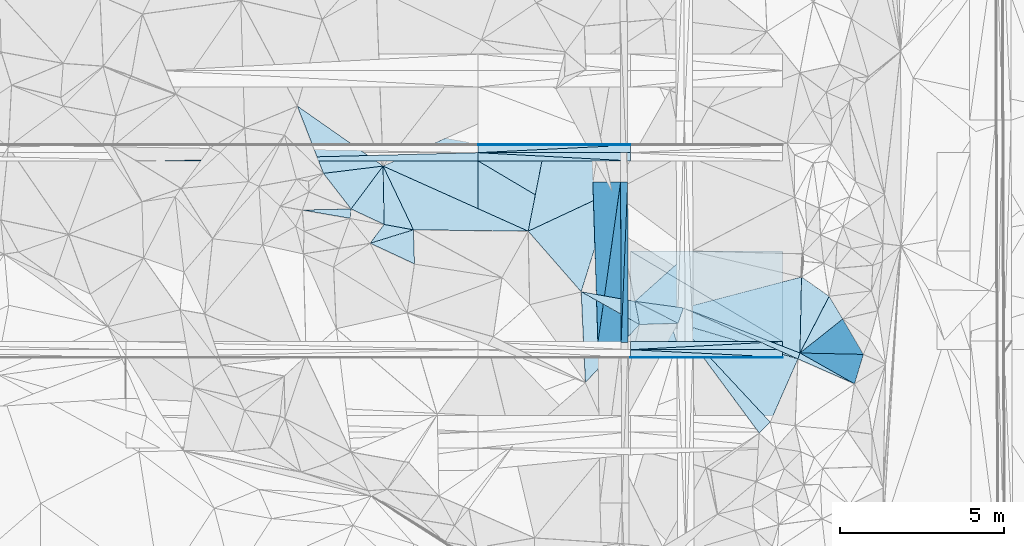
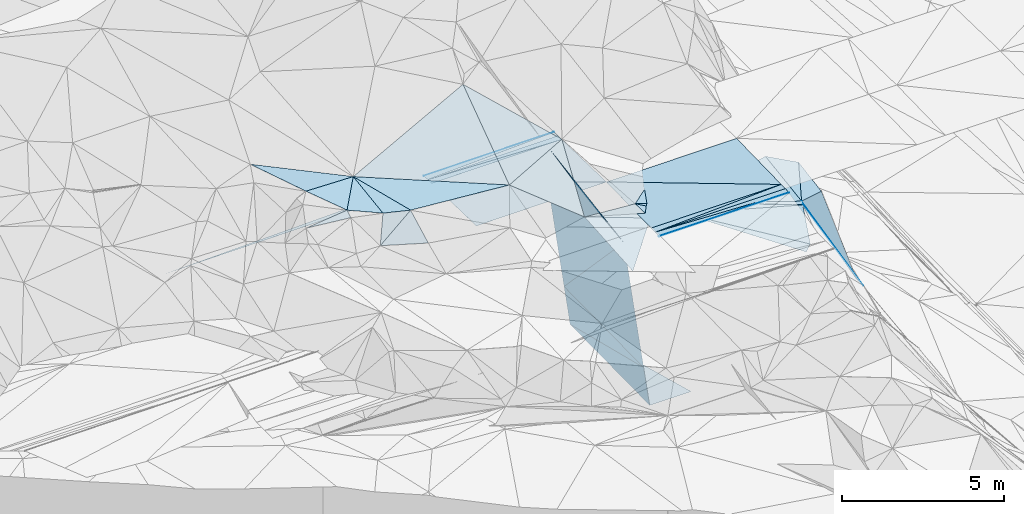
# One storey, part 61 of 275: 48 plates.
"""IFC2X3 building model written with IfcOpenShell, lengths in millimetres."""

from ifc_helpers import new_model, si_unit, frame, origin_with_axes, place, context, subcontext, project, spatial, polyline, outline, extrude, material, type_object, element, save


model = new_model("IFC2X3")

# Units and contexts
model_context = context("Model", 3, precision=1e-05, world=origin_with_axes())
body_context = subcontext(model_context, "Body", "Model", "MODEL_VIEW")
ifc_project = project(units=[si_unit("LENGTHUNIT", "METRE", prefix="MILLI"), si_unit("AREAUNIT", "SQUARE_METRE"), si_unit("VOLUMEUNIT", "CUBIC_METRE"), si_unit("MASSUNIT", "GRAM", prefix="KILO"), si_unit("TIMEUNIT", "SECOND"), si_unit("PLANEANGLEUNIT", "RADIAN"), si_unit("SOLIDANGLEUNIT", "STERADIAN"), si_unit("THERMODYNAMICTEMPERATUREUNIT", "DEGREE_CELSIUS"), si_unit("LUMINOUSINTENSITYUNIT", "LUMEN")], contexts=[model_context])

# Site, building, storey
site_placement = place(None, origin_with_axes())
site = spatial("IfcSite", under=ifc_project, at=site_placement, CompositionType="ELEMENT")
building_placement = place(site_placement, origin_with_axes())
building = spatial("IfcBuilding", under=site, at=building_placement, Name="Undefined", CompositionType="ELEMENT")
storey_placement = place(building_placement, origin_with_axes())
storey = spatial("IfcBuildingStorey", under=building, at=storey_placement, Name="Undefined", CompositionType="ELEMENT", Elevation=0.0)

# Plates
ifc_material = material()
plate_type_1 = type_object("IfcPlateType", PredefinedType="NOTDEFINED")
plate_1_placement = place(storey_placement, frame((-100830.589611758, 60542.6808444569, 49114.2541550051), z_axis=(0.00445958464702882, 0.0249916867668201, -0.999677711913857), x_axis=(-0.999990054538875, 5.7357962472799e-05, -0.00445954408009802)))
element("IfcPlate", 1, at=plate_1_placement, inside=storey, type_object=plate_type_1, material=ifc_material, Name="00_PR", context=body_context, shape_type="SweptSolid", body=[
    extrude(outline(polyline([(0.0, 0.0), (4638.8154296875, -1.62399373948574e-08), (4638.5087890625, 2750.85913085938), (0.0, 0.0)])), frame((-8.85201319254618e-08, 2.18876761149539e-07, -0.5000001331573), z_axis=(0.0, 0.0, 1.0), x_axis=(1.0, 0.0, 0.0)), (0.0, 0.0, 1.0), 1.0),
])
plate_2_placement = place(storey_placement, frame((-110107.812661228, 66043.1876384152, 49060.924162094), z_axis=(0.00703319088817578, -0.0249919755993871, -0.999662910876246), x_axis=(0.99997523963564, -5.72709999785377e-05, 0.00703681999743575)))
element("IfcPlate", 2, at=plate_2_placement, inside=storey, type_object=plate_type_1, material=ifc_material, Name="00_PR", context=body_context, shape_type="SweptSolid", body=[
    extrude(outline(polyline([(0.0, 0.0), (4638.88525390625, 2.71393219009042e-09), (4639.36865234375, 2750.85913085938), (0.0, 0.0)])), frame((-8.85201319254618e-08, 2.18876761149539e-07, -0.5000001331573), z_axis=(0.0, 0.0, 1.0), x_axis=(1.0, 0.0, 0.0)), (0.0, 0.0, 1.0), 1.0),
])
plate_3_placement = place(storey_placement, frame((-105469.201325438, 63292.9469357661, 49162.3171559692), z_axis=(0.00445958464702882, 0.0249916867668201, -0.999677711913857), x_axis=(0.999990054538811, -5.7357974325105e-05, 0.00445954409423353)))
element("IfcPlate", 3, at=plate_3_placement, inside=storey, type_object=plate_type_1, material=ifc_material, Name="00_PR", context=body_context, shape_type="SweptSolid", body=[
    extrude(outline(polyline([(0.0, 0.0), (4638.8154296875, -1.62399373948574e-08), (4638.5087890625, 2750.85913085938), (0.0, 0.0)])), frame((-8.85201319254618e-08, 2.18876761149539e-07, -0.5000001331573), z_axis=(0.0, 0.0, 1.0), x_axis=(1.0, 0.0, 0.0)), (0.0, 0.0, 1.0), 1.0),
])
plate_4_placement = place(storey_placement, frame((-105469.200038156, 63292.9219439017, 49162.3171634529), z_axis=(0.00703319088817578, -0.0249919755993871, -0.999662910876246), x_axis=(-0.999975239635043, 5.72709690146696e-05, -0.00703682008264182)))
element("IfcPlate", 4, at=plate_4_placement, inside=storey, type_object=plate_type_1, material=ifc_material, Name="00_PR", context=body_context, shape_type="SweptSolid", body=[
    extrude(outline(polyline([(0.0, 0.0), (4638.88525390625, 2.71393219009042e-09), (4639.36865234375, 2750.85913085938), (0.0, 0.0)])), frame((-8.85201319254618e-08, 2.18876761149539e-07, -0.5000001331573), z_axis=(0.0, 0.0, 1.0), x_axis=(1.0, 0.0, 0.0)), (0.0, 0.0, 1.0), 1.0),
])
plate_type_2 = type_object("IfcPlateType", PredefinedType="NOTDEFINED")
plate_5_placement = place(storey_placement, frame((-105750.211963608, 60512.2783129229, 43954.7062906531), z_axis=(-0.989949462688616, -0.000459142367813095, -0.141420827712214), x_axis=(0.0389520529233539, 0.960431065069933, -0.275780541049744)))
element("IfcPlate", 5, at=plate_5_placement, inside=storey, type_object=plate_type_2, material=ifc_material, Name="00_PR", context=body_context, shape_type="SweptSolid", body=[
    extrude(outline(polyline([(0.0, 0.0), (5087.06298828125, -9.02218744158745e-10), (422.780456542969, 1455.05151367188), (0.0, 0.0)])), frame((-8.85201319254618e-08, 2.18876761149539e-07, -0.5000001331573), z_axis=(0.0, 0.0, 1.0), x_axis=(1.0, 0.0, 0.0)), (0.0, 0.0, 1.0), 1.0),
])
plate_6_placement = place(storey_placement, frame((-105552.060415257, 65398.0516855219, 42551.7932908244), z_axis=(-0.989949462688616, -0.000459142367813095, -0.141420827712214), x_axis=(-0.0389520529001287, -0.960431065076031, 0.275780541031789)))
element("IfcPlate", 6, at=plate_6_placement, inside=storey, type_object=plate_type_2, material=ifc_material, Name="00_PR", context=body_context, shape_type="SweptSolid", body=[
    extrude(outline(polyline([(0.0, 0.0), (5087.06298828125, -9.02218744158745e-10), (422.614044189453, 1455.09997558594), (0.0, 0.0)])), frame((-8.85201319254618e-08, 2.18876761149539e-07, -0.5000001331573), z_axis=(0.0, 0.0, 1.0), x_axis=(1.0, 0.0, 0.0)), (0.0, 0.0, 1.0), 1.0),
])
plate_type_3 = type_object("IfcPlateType", PredefinedType="NOTDEFINED")
for number, where, z_axis, x_axis, name in (
    (7, (-100830.589611758, 60542.6808444569, 49114.2541550051), (0.00445958464702882, 0.0249916867668201, -0.999677711913857), (-5.72779639714365e-05, -0.999687644771442, -0.0249921909916474), "00_PR"),
    (8, (-105469.373205973, 60292.9469153299, 49087.3171553601), (0.00445958464702882, 0.0249916867668201, -0.999677711913857), (5.72779615274784e-05, 0.999687644771121, 0.0249921910044782), "00_PR"),
):
    element("IfcPlate", number, at=place(storey_placement, frame(where, z_axis=z_axis, x_axis=x_axis)), inside=storey, type_object=plate_type_3, material=ifc_material, Name=name, context=body_context, shape_type="SweptSolid", body=[
        extrude(outline(polyline([(0.0, 0.0), (250.078109741211, 1.02591002359986e-09), (250.594833374023, 4638.8154296875), (0.0, 0.0)])), frame((-8.85201319254618e-08, 2.18876761149539e-07, -0.5000001331573), z_axis=(0.0, 0.0, 1.0), x_axis=(1.0, 0.0, 0.0)), (0.0, 0.0, 1.0), 1.0),
    ])
for number, where, z_axis, x_axis, name in (
    (9, (-105469.042478086, 66042.9219653409, 49093.5671630023), (0.00703319088817578, -0.0249919755993871, -0.999662910876246), (-0.999975239635043, 5.72709690146696e-05, -0.00703682008264182), "00_PR"),
    (10, (-110107.798337881, 66293.1876381084, 49054.6741627501), (0.00703319088817578, -0.0249919755993871, -0.999662910876246), (0.99997523963564, -5.72709999785377e-05, 0.00703681999743575), "00_PR"),
):
    element("IfcPlate", number, at=place(storey_placement, frame(where, z_axis=z_axis, x_axis=x_axis)), inside=storey, type_object=plate_type_3, material=ifc_material, Name=name, context=body_context, shape_type="SweptSolid", body=[
        extrude(outline(polyline([(0.0, 0.0), (4638.88525390625, 2.71393219009042e-09), (4638.92919921875, 250.078109741211), (0.0, 0.0)])), frame((-8.85201319254618e-08, 2.18876761149539e-07, -0.5000001331573), z_axis=(0.0, 0.0, 1.0), x_axis=(1.0, 0.0, 0.0)), (0.0, 0.0, 1.0), 1.0),
    ])
plate_7_placement = place(storey_placement, frame((-119776.166734468, 66043.7427297711, 48980.4271662069), z_axis=(0.00832149793297365, -0.0249918019511436, -0.9996530210565), x_axis=(0.999637887760612, 0.0257907600207236, 0.00767659110902143)))
element("IfcPlate", 11, at=plate_7_placement, inside=storey, type_object=plate_type_3, material=ifc_material, Name="00_PR", context=body_context, shape_type="SweptSolid", body=[
    extrude(outline(polyline([(0.0, 0.0), (9671.87109375, 1.0710209608078e-08), (9665.45703125, 249.995849609375), (0.0, 0.0)])), frame((-8.85201319254618e-08, 2.18876761149539e-07, -0.5000001331573), z_axis=(0.0, 0.0, 1.0), x_axis=(1.0, 0.0, 0.0)), (0.0, 0.0, 1.0), 1.0),
])
plate_type_4 = type_object("IfcPlateType", PredefinedType="NOTDEFINED")
plate_8_placement = place(storey_placement, frame((-105469.387528918, 60042.9593598603, 49074.8176223799), z_axis=(0.00445706800429549, 0.0498862544457176, -0.998744960519042), x_axis=(0.999980022930594, 0.00425411303893104, 0.00467506812571352)))
element("IfcPlate", 12, at=plate_8_placement, inside=storey, type_object=plate_type_4, material=ifc_material, Name="00_PR", context=body_context, shape_type="SweptSolid", body=[
    extrude(outline(polyline([(0.0, 0.0), (4638.86279296875, -3.32511262968183e-09), (4638.77197265625, 20.0250549316406), (0.0, 0.0)])), frame((-8.85201319254618e-08, 2.18876761149539e-07, -0.5000001331573), z_axis=(0.0, 0.0, 1.0), x_axis=(1.0, 0.0, 0.0)), (0.0, 0.0, 1.0), 1.0),
])
plate_9_placement = place(storey_placement, frame((-105469.386444849, 60062.9597101127, 49075.81762361), z_axis=(0.00445684475219927, 0.0499360670244888, -0.998742472184387), x_axis=(0.999990054538811, -5.7357974325105e-05, 0.00445954409423353)))
element("IfcPlate", 13, at=plate_9_placement, inside=storey, type_object=plate_type_4, material=ifc_material, Name="00_PR", context=body_context, shape_type="SweptSolid", body=[
    extrude(outline(polyline([(0.0, 0.0), (4638.8154296875, -1.62399373948574e-08), (-0.00440195994451642, 20.0253086090088), (0.0, 0.0)])), frame((-8.85201319254618e-08, 2.18876761149539e-07, -0.5000001331573), z_axis=(0.0, 0.0, 1.0), x_axis=(1.0, 0.0, 0.0)), (0.0, 0.0, 1.0), 1.0),
])
plate_10_placement = place(storey_placement, frame((-105469.013835611, 66542.9094938357, 49074.8176311458), z_axis=(0.00702518057718914, -0.0499383774070755, -0.998727593140295), x_axis=(-7.46349832174646e-05, -0.998752262639263, 0.0499390859204745)))
element("IfcPlate", 14, at=plate_10_placement, inside=storey, type_object=plate_type_4, material=ifc_material, Name="00_PR", context=body_context, shape_type="SweptSolid", body=[
    extrude(outline(polyline([(0.0, 0.0), (20.0243949890137, 1.30967237055302e-10), (18.4751071929932, 4638.884765625), (0.0, 0.0)])), frame((-8.85201319254618e-08, 2.18876761149539e-07, -0.5000001331573), z_axis=(0.0, 0.0, 1.0), x_axis=(1.0, 0.0, 0.0)), (0.0, 0.0, 1.0), 1.0),
])
plate_11_placement = place(storey_placement, frame((-110107.785515668, 66523.1757512624, 49043.1746305626), z_axis=(0.00702518057718914, -0.0499383774070755, -0.998727593140295), x_axis=(7.46349675932083e-05, 0.998752262639191, -0.0499390859219244)))
element("IfcPlate", 15, at=plate_11_placement, inside=storey, type_object=plate_type_4, material=ifc_material, Name="00_PR", context=body_context, shape_type="SweptSolid", body=[
    extrude(outline(polyline([(0.0, 0.0), (20.0243949890137, 1.30967237055302e-10), (18.4750175476074, 4638.884765625), (0.0, 0.0)])), frame((-8.85201319254618e-08, 2.18876761149539e-07, -0.5000001331573), z_axis=(0.0, 0.0, 1.0), x_axis=(1.0, 0.0, 0.0)), (0.0, 0.0, 1.0), 1.0),
])
plate_type_5 = type_object("IfcPlateType", PredefinedType="NOTDEFINED")
plate_12_placement = place(storey_placement, frame((-112075.543551472, 63943.371448506, 50019.5088277539), z_axis=(-0.0790529331434514, 0.169753305457611, -0.982310770096527), x_axis=(-0.97775423595403, 0.178846539819995, 0.109592742772353)))
element("IfcPlate", 16, at=plate_12_placement, inside=storey, type_object=plate_type_5, material=ifc_material, Name="00", context=body_context, shape_type="SweptSolid", body=[
    extrude(outline(polyline([(0.0, 0.0), (912.469177246094, -5.08589437231421e-09), (1295.93420410156, 1764.86669921875), (0.0, 0.0)])), frame((-8.85201319254618e-08, 2.18876761149539e-07, -0.5000001331573), z_axis=(0.0, 0.0, 1.0), x_axis=(1.0, 0.0, 0.0)), (0.0, 0.0, 1.0), 1.0),
])
plate_type_6 = type_object("IfcPlateType", PredefinedType="NOTDEFINED")
for number, where, z_axis, x_axis, name in (
    (17, (-100830.617173414, 60062.6936343735, 49096.5046243823), (0.00445684475219927, 0.0499360670244888, -0.998742472184387), (-0.999990054538875, 5.7357962472799e-05, -0.00445954408009802), "00_PR"),
    (18, (-105469.373208307, 60292.9593863824, 49087.317623531), (0.00445684475219927, 0.0499360670244888, -0.998742472184387), (0.999990054538811, -5.7357974325105e-05, 0.00445954409423353), "00_PR"),
):
    element("IfcPlate", number, at=place(storey_placement, frame(where, z_axis=z_axis, x_axis=x_axis)), inside=storey, type_object=plate_type_6, material=ifc_material, Name=name, context=body_context, shape_type="SweptSolid", body=[
        extrude(outline(polyline([(0.0, 0.0), (4638.8154296875, -1.62399373948574e-08), (4638.76416015625, 230.286987304688), (0.0, 0.0)])), frame((-8.85201319254618e-08, 2.18876761149539e-07, -0.5000001331573), z_axis=(0.0, 0.0, 1.0), x_axis=(1.0, 0.0, 0.0)), (0.0, 0.0, 1.0), 1.0),
    ])
for number, where, z_axis, x_axis, name in (
    (19, (-105469.015328901, 66522.9100819823, 49075.817631294), (0.00702518115586618, -0.0499366476229546, -0.998727679627389), (-5.57099735653163e-05, -0.998752343725082, 0.0499374889242045), "00_PR"),
    (20, (-110107.798341937, 66293.1751620054, 49054.6746301273), (0.00702518115586618, -0.0499366476229546, -0.998727679627389), (5.57099558727869e-05, 0.998752343723243, -0.049937488961006), "00_PR"),
):
    element("IfcPlate", number, at=place(storey_placement, frame(where, z_axis=z_axis, x_axis=x_axis)), inside=storey, type_object=plate_type_6, material=ifc_material, Name=name, context=body_context, shape_type="SweptSolid", body=[
        extrude(outline(polyline([(0.0, 0.0), (230.28791809082, 9.89530235528946e-10), (228.650894165039, 4638.884765625), (0.0, 0.0)])), frame((-8.85201319254618e-08, 2.18876761149539e-07, -0.5000001331573), z_axis=(0.0, 0.0, 1.0), x_axis=(1.0, 0.0, 0.0)), (0.0, 0.0, 1.0), 1.0),
    ])
plate_type_7 = type_object("IfcPlateType", PredefinedType="NOTDEFINED")
plate_13_placement = place(storey_placement, frame((-112999.778043075, 65885.4205597464, 50429.5035751612), z_axis=(-0.117700150187299, -0.0215803549464643, -0.992814666957671), x_axis=(-0.985437579645011, -0.121008542112086, 0.119455888759363)))
element("IfcPlate", 21, at=plate_13_placement, inside=storey, type_object=plate_type_7, material=ifc_material, Name="00", context=body_context, shape_type="SweptSolid", body=[
    extrude(outline(polyline([(0.0, 0.0), (1841.68395996094, 1.0433723218739e-08), (2385.75122070313, 2134.59375), (0.0, 0.0)])), frame((-8.85201319254618e-08, 2.18876761149539e-07, -0.5000001331573), z_axis=(0.0, 0.0, 1.0), x_axis=(1.0, 0.0, 0.0)), (0.0, 0.0, 1.0), 1.0),
])
plate_type_8 = type_object("IfcPlateType", PredefinedType="NOTDEFINED")
plate_14_placement = place(storey_placement, frame((-106016.707017982, 65102.1914454175, 49869.5117628019), z_axis=(-0.059004241128737, 0.207589575508006, -0.976434876307287), x_axis=(-0.905266208865445, -0.423375243554277, -0.0353057251977836)))
element("IfcPlate", 22, at=plate_14_placement, inside=storey, type_object=plate_type_8, material=ifc_material, Name="00", context=body_context, shape_type="SweptSolid", body=[
    extrude(outline(polyline([(0.0, 0.0), (2832.40185546875, -1.62981450557709e-09), (197.147171020508, 3649.33325195313), (0.0, 0.0)])), frame((-8.85201319254618e-08, 2.18876761149539e-07, -0.5000001331573), z_axis=(0.0, 0.0, 1.0), x_axis=(1.0, 0.0, 0.0)), (0.0, 0.0, 1.0), 1.0),
])
plate_type_9 = type_object("IfcPlateType", PredefinedType="NOTDEFINED")
plate_15_placement = place(storey_placement, frame((-105766.345772115, 65397.4307514834, 44051.793290675), z_axis=(-0.989949462688616, -0.000459142367813095, -0.141420827712214), x_axis=(-0.0999028479454266, -0.705520009970533, 0.701613096017721)))
element("IfcPlate", 23, at=plate_15_placement, inside=storey, type_object=plate_type_9, material=ifc_material, Name="00_PR", context=body_context, shape_type="SweptSolid", body=[
    extrude(outline(polyline([(0.0, 0.0), (6927.90966796875, -9.61881596595049e-09), (4237.13232421875, 4214.724609375), (0.0, 0.0)])), frame((-8.85201319254618e-08, 2.18876761149539e-07, -0.5000001331573), z_axis=(0.0, 0.0, 1.0), x_axis=(1.0, 0.0, 0.0)), (0.0, 0.0, 1.0), 1.0),
])
plate_type_10 = type_object("IfcPlateType", PredefinedType="NOTDEFINED")
plate_16_placement = place(storey_placement, frame((-106458.463654874, 60509.6520100002, 48912.5052908891), z_axis=(-0.989949462688616, -0.000459142367813095, -0.141420827712214), x_axis=(0.0999028479470844, 0.705520009971267, -0.701613096016747)))
element("IfcPlate", 24, at=plate_16_placement, inside=storey, type_object=plate_type_10, material=ifc_material, Name="00_PR", context=body_context, shape_type="SweptSolid", body=[
    extrude(outline(polyline([(0.0, 0.0), (6927.90966796875, -9.61881596595049e-09), (3551.06591796875, 3531.47680664063), (0.0, 0.0)])), frame((-8.85201319254618e-08, 2.18876761149539e-07, -0.5000001331573), z_axis=(0.0, 0.0, 1.0), x_axis=(1.0, 0.0, 0.0)), (0.0, 0.0, 1.0), 1.0),
])
plate_type_11 = type_object("IfcPlateType", PredefinedType="NOTDEFINED")
plate_17_placement = place(storey_placement, frame((-105535.432843568, 60513.0827354153, 42454.2770998396), z_axis=(-7.36736984133596e-05, 0.0198704310227725, -0.999802560780455), x_axis=(-0.00330182709453269, 0.999797108690456, 0.0198705659718521)))
element("IfcPlate", 25, at=plate_17_placement, inside=storey, type_object=plate_type_11, material=ifc_material, Name="00_PR", context=body_context, shape_type="SweptSolid", body=[
    extrude(outline(polyline([(0.0, 0.0), (4885.97021484375, 1.59925548359752e-08), (0.599608778953552, 1480.00085449219), (0.0, 0.0)])), frame((-8.85201319254618e-08, 2.18876761149539e-07, -0.5000001331573), z_axis=(0.0, 0.0, 1.0), x_axis=(1.0, 0.0, 0.0)), (0.0, 0.0, 1.0), 1.0),
])
plate_type_12 = type_object("IfcPlateType", PredefinedType="NOTDEFINED")
plate_18_placement = place(storey_placement, frame((-104017.21366671, 61098.7763190205, 48799.5053855801), z_axis=(-0.0392953949728574, 0.141091818847094, -0.989216341650473), x_axis=(0.331602282612743, 0.935719227536978, 0.120289040995509)))
element("IfcPlate", 26, at=plate_18_placement, inside=storey, type_object=plate_type_12, material=ifc_material, Name="00", context=body_context, shape_type="SweptSolid", body=[
    extrude(outline(polyline([(0.0, 0.0), (498.798553466797, -4.65661287307739e-10), (157.979614257813, 3817.84521484375), (0.0, 0.0)])), frame((-8.85201319254618e-08, 2.18876761149539e-07, -0.5000001331573), z_axis=(0.0, 0.0, 1.0), x_axis=(1.0, 0.0, 0.0)), (0.0, 0.0, 1.0), 1.0),
])
plate_type_13 = type_object("IfcPlateType", PredefinedType="NOTDEFINED")
plate_19_placement = place(storey_placement, frame((-113393.090444931, 63535.9249403799, 49389.5852132286), z_axis=(0.240733730417265, 0.503894330570078, -0.829540701026008), x_axis=(0.868983475871254, 0.268807500180116, 0.415463893147925)))
element("IfcPlate", 27, at=plate_19_placement, inside=storey, type_object=plate_type_13, material=ifc_material, Name="00", context=body_context, shape_type="SweptSolid", body=[
    extrude(outline(polyline([(0.0, 0.0), (1516.37731933594, -6.17001205682755e-09), (1007.73077392578, 1095.16149902344), (0.0, 0.0)])), frame((-8.85201319254618e-08, 2.18876761149539e-07, -0.5000001331573), z_axis=(0.0, 0.0, 1.0), x_axis=(1.0, 0.0, 0.0)), (0.0, 0.0, 1.0), 1.0),
])
plate_type_14 = type_object("IfcPlateType", PredefinedType="NOTDEFINED")
plate_20_placement = place(storey_placement, frame((-98642.9182101331, 59254.5877800958, 45319.7455027577), z_axis=(-0.804662697907066, 0.305703089194704, -0.508982871866763), x_axis=(-0.466390420264055, 0.205051745927796, 0.860484606124875)))
element("IfcPlate", 28, at=plate_20_placement, inside=storey, type_object=plate_type_14, material=ifc_material, Name="00", context=body_context, shape_type="SweptSolid", body=[
    extrude(outline(polyline([(0.0, 0.0), (3695.59204101563, -7.83984432928264e-09), (3712.17919921875, 190.5908203125), (0.0, 0.0)])), frame((-8.85201319254618e-08, 2.18876761149539e-07, -0.5000001331573), z_axis=(0.0, 0.0, 1.0), x_axis=(1.0, 0.0, 0.0)), (0.0, 0.0, 1.0), 1.0),
])
plate_type_15 = type_object("IfcPlateType", PredefinedType="NOTDEFINED")
plate_21_placement = place(storey_placement, frame((-100256.673082127, 62509.8225528499, 48779.5062571935), z_axis=(-0.10560587002909, 0.117224859533754, -0.987474421199198), x_axis=(0.808496435731209, -0.568022487534711, -0.153895961820997)))
element("IfcPlate", 29, at=plate_21_placement, inside=storey, type_object=plate_type_15, material=ifc_material, Name="00", context=body_context, shape_type="SweptSolid", body=[
    extrude(outline(polyline([(0.0, 0.0), (1039.66345214844, -1.09957909444347e-09), (1319.46545410156, 1924.13891601563), (0.0, 0.0)])), frame((-8.85201319254618e-08, 2.18876761149539e-07, -0.5000001331573), z_axis=(0.0, 0.0, 1.0), x_axis=(1.0, 0.0, 0.0)), (0.0, 0.0, 1.0), 1.0),
])
plate_type_16 = type_object("IfcPlateType", PredefinedType="NOTDEFINED")
plate_22_placement = place(storey_placement, frame((-113975.057644513, 64579.6790933694, 50299.5155681113), z_axis=(-0.142340174572394, 0.202754351842892, -0.968829163223047), x_axis=(-0.593640454845898, 0.765735069479716, 0.247468813670027)))
element("IfcPlate", 30, at=plate_22_placement, inside=storey, type_object=plate_type_16, material=ifc_material, Name="00", context=body_context, shape_type="SweptSolid", body=[
    extrude(outline(polyline([(0.0, 0.0), (1414.31958007813, 4.05270839110017e-09), (453.150756835938, 1570.97241210938), (0.0, 0.0)])), frame((-8.85201319254618e-08, 2.18876761149539e-07, -0.5000001331573), z_axis=(0.0, 0.0, 1.0), x_axis=(1.0, 0.0, 0.0)), (0.0, 0.0, 1.0), 1.0),
])
plate_type_17 = type_object("IfcPlateType", PredefinedType="NOTDEFINED")
plate_23_placement = place(storey_placement, frame((-100366.138456112, 60012.2617356768, 48499.5026877407), z_axis=(-0.0677690805312491, 0.078442740170676, -0.994612531711955), x_axis=(-0.909382122257498, 0.405219802891558, 0.093920535895917)))
element("IfcPlate", 31, at=plate_23_placement, inside=storey, type_object=plate_type_17, material=ifc_material, Name="00", context=body_context, shape_type="SweptSolid", body=[
    extrude(outline(polyline([(0.0, 0.0), (3833.02758789063, 2.02126102522016e-08), (17.4796562194824, 190.511047363281), (0.0, 0.0)])), frame((-8.85201319254618e-08, 2.18876761149539e-07, -0.5000001331573), z_axis=(0.0, 0.0, 1.0), x_axis=(1.0, 0.0, 0.0)), (0.0, 0.0, 1.0), 1.0),
])
plate_type_18 = type_object("IfcPlateType", PredefinedType="NOTDEFINED")
plate_24_placement = place(storey_placement, frame((-98642.9557746897, 59254.4597247195, 45319.7636102323), z_axis=(-0.879790226201069, 0.049592005574898, -0.472768221081039), x_axis=(-0.446937622290595, 0.252456255951978, 0.858203123166036)))
element("IfcPlate", 32, at=plate_24_placement, inside=storey, type_object=plate_type_18, material=ifc_material, Name="00", context=body_context, shape_type="SweptSolid", body=[
    extrude(outline(polyline([(0.0, 0.0), (3717.06884765625, -1.30239641293883e-09), (-246.699768066406, 991.68505859375), (0.0, 0.0)])), frame((-8.85201319254618e-08, 2.18876761149539e-07, -0.5000001331573), z_axis=(0.0, 0.0, 1.0), x_axis=(1.0, 0.0, 0.0)), (0.0, 0.0, 1.0), 1.0),
])
plate_type_19 = type_object("IfcPlateType", PredefinedType="NOTDEFINED")
plate_25_placement = place(storey_placement, frame((-99416.3844420872, 61919.4013482888, 48619.674024694), z_axis=(-0.65664187802816, 0.379205227066634, -0.651939291487324), x_axis=(0.360827201209511, -0.601110872837937, -0.713070437911518)))
element("IfcPlate", 33, at=plate_25_placement, inside=storey, type_object=plate_type_19, material=ifc_material, Name="00", context=body_context, shape_type="SweptSolid", body=[
    extrude(outline(polyline([(0.0, 0.0), (1149.95654296875, -8.65838956087828e-10), (795.856201171875, 1774.03857421875), (0.0, 0.0)])), frame((-8.85201319254618e-08, 2.18876761149539e-07, -0.5000001331573), z_axis=(0.0, 0.0, 1.0), x_axis=(1.0, 0.0, 0.0)), (0.0, 0.0, 1.0), 1.0),
])
plate_type_20 = type_object("IfcPlateType", PredefinedType="NOTDEFINED")
plate_26_placement = place(storey_placement, frame((-103612.934127048, 63300.2644408861, 49029.5161459153), z_axis=(-0.2189577288604, 0.124992341768, -0.967695420817752), x_axis=(-0.135824735712832, -0.986009739544851, -0.0966252280268158)))
element("IfcPlate", 34, at=plate_26_placement, inside=storey, type_object=plate_type_20, material=ifc_material, Name="00", context=body_context, shape_type="SweptSolid", body=[
    extrude(outline(polyline([(0.0, 0.0), (1759.37487792969, -7.23230186849833e-09), (1728.11376953125, 1532.94580078125), (0.0, 0.0)])), frame((-8.85201319254618e-08, 2.18876761149539e-07, -0.5000001331573), z_axis=(0.0, 0.0, 1.0), x_axis=(1.0, 0.0, 0.0)), (0.0, 0.0, 1.0), 1.0),
])
plate_type_21 = type_object("IfcPlateType", PredefinedType="NOTDEFINED")
plate_27_placement = place(storey_placement, frame((-98372.0362041418, 60150.7618509693, 44909.8102951598), z_axis=(-0.693474112092788, 0.612495419578175, -0.379398229902137), x_axis=(-0.472871507049747, 0.010371318848494, 0.881070356762639)))
element("IfcPlate", 35, at=plate_27_placement, inside=storey, type_object=plate_type_21, material=ifc_material, Name="00", context=body_context, shape_type="SweptSolid", body=[
    extrude(outline(polyline([(0.0, 0.0), (4085.93920898438, 1.16215232992545e-08), (2855.1083984375, 1325.76599121094), (0.0, 0.0)])), frame((-8.85201319254618e-08, 2.18876761149539e-07, -0.5000001331573), z_axis=(0.0, 0.0, 1.0), x_axis=(1.0, 0.0, 0.0)), (0.0, 0.0, 1.0), 1.0),
])
plate_type_22 = type_object("IfcPlateType", PredefinedType="NOTDEFINED")
plate_28_placement = place(storey_placement, frame((-112999.767085263, 65885.5159430825, 50429.5095361476), z_axis=(-0.0958116104936599, 0.169207726553735, -0.980912269557848), x_axis=(0.0177429412166008, -0.984998948198246, -0.171645740073366)))
element("IfcPlate", 36, at=plate_28_placement, inside=storey, type_object=plate_type_22, material=ifc_material, Name="00", context=body_context, shape_type="SweptSolid", body=[
    extrude(outline(polyline([(0.0, 0.0), (1806.04541015625, -1.06083462014794e-08), (1291.27429199219, 1002.95098876953), (0.0, 0.0)])), frame((-8.85201319254618e-08, 2.18876761149539e-07, -0.5000001331573), z_axis=(0.0, 0.0, 1.0), x_axis=(1.0, 0.0, 0.0)), (0.0, 0.0, 1.0), 1.0),
])
plate_type_23 = type_object("IfcPlateType", PredefinedType="NOTDEFINED")
plate_29_placement = place(storey_placement, frame((-103851.894776582, 61565.5394520234, 48859.5207982195), z_axis=(-0.20700404168478, 0.196562069198277, -0.958390671740214), x_axis=(-0.331602282617965, -0.935719227532981, -0.120289041012211)))
element("IfcPlate", 37, at=plate_29_placement, inside=storey, type_object=plate_type_23, material=ifc_material, Name="00", context=body_context, shape_type="SweptSolid", body=[
    extrude(outline(polyline([(0.0, 0.0), (498.798553466797, -4.65661287307739e-10), (259.423370361328, 1511.15832519531), (0.0, 0.0)])), frame((-8.85201319254618e-08, 2.18876761149539e-07, -0.5000001331573), z_axis=(0.0, 0.0, 1.0), x_axis=(1.0, 0.0, 0.0)), (0.0, 0.0, 1.0), 1.0),
])
plate_type_24 = type_object("IfcPlateType", PredefinedType="NOTDEFINED")
plate_30_placement = place(storey_placement, frame((-100303.840095889, 60192.8905081665, 48509.5041072006), z_axis=(-0.0527083777040024, 0.116648397614536, -0.991773652732202), x_axis=(-0.928716742422746, 0.359293409953107, 0.0916158169092598)))
element("IfcPlate", 38, at=plate_30_placement, inside=storey, type_object=plate_type_24, material=ifc_material, Name="00", context=body_context, shape_type="SweptSolid", body=[
    extrude(outline(polyline([(0.0, 0.0), (3820.30102539063, -1.56069290824234e-09), (813.365234375, 2186.71826171875), (0.0, 0.0)])), frame((-8.85201319254618e-08, 2.18876761149539e-07, -0.5000001331573), z_axis=(0.0, 0.0, 1.0), x_axis=(1.0, 0.0, 0.0)), (0.0, 0.0, 1.0), 1.0),
])
plate_type_25 = type_object("IfcPlateType", PredefinedType="NOTDEFINED")
plate_31_placement = place(storey_placement, frame((-104017.235996699, 61098.7179079783, 48799.5019068744), z_axis=(-0.0839552367197321, 0.0242698698900185, -0.996173926401839), x_axis=(0.679933816246154, -0.729420230959822, -0.0750741779273101)))
element("IfcPlate", 39, at=plate_31_placement, inside=storey, type_object=plate_type_25, material=ifc_material, Name="00", context=body_context, shape_type="SweptSolid", body=[
    extrude(outline(polyline([(0.0, 0.0), (4129.24951171875, 1.37515598908067e-08), (4144.04638671875, 471.890930175781), (0.0, 0.0)])), frame((-8.85201319254618e-08, 2.18876761149539e-07, -0.5000001331573), z_axis=(0.0, 0.0, 1.0), x_axis=(1.0, 0.0, 0.0)), (0.0, 0.0, 1.0), 1.0),
])
plate_type_26 = type_object("IfcPlateType", PredefinedType="NOTDEFINED")
plate_32_placement = place(storey_placement, frame((-100366.140124036, 60012.2406780742, 48499.5015900235), z_axis=(-0.0710965065984439, 0.0363214717907051, -0.996807924043772), x_axis=(-0.401244675908723, -0.915958558288017, -0.00475705306268197)))
element("IfcPlate", 40, at=plate_32_placement, inside=storey, type_object=plate_type_26, material=ifc_material, Name="00", context=body_context, shape_type="SweptSolid", body=[
    extrude(outline(polyline([(0.0, 0.0), (2102.14184570313, -6.11180439591408e-09), (468.379455566406, 3792.29760742188), (0.0, 0.0)])), frame((-8.85201319254618e-08, 2.18876761149539e-07, -0.5000001331573), z_axis=(0.0, 0.0, 1.0), x_axis=(1.0, 0.0, 0.0)), (0.0, 0.0, 1.0), 1.0),
])
plate_type_27 = type_object("IfcPlateType", PredefinedType="NOTDEFINED")
plate_33_placement = place(storey_placement, frame((-105192.136097785, 61060.4861985266, 49059.5200014019), z_axis=(-0.218177360307581, 0.175582850829231, -0.959984011295967), x_axis=(-0.185823370285179, 0.958210511262317, 0.217490899033194)))
element("IfcPlate", 41, at=plate_33_placement, inside=storey, type_object=plate_type_27, material=ifc_material, Name="00", context=body_context, shape_type="SweptSolid", body=[
    extrude(outline(polyline([(0.0, 0.0), (735.662963867188, 1.65891833603382e-09), (-238.152542114258, 1180.07763671875), (0.0, 0.0)])), frame((-8.85201319254618e-08, 2.18876761149539e-07, -0.5000001331573), z_axis=(0.0, 0.0, 1.0), x_axis=(1.0, 0.0, 0.0)), (0.0, 0.0, 1.0), 1.0),
])
plate_34_placement = place(storey_placement, frame((-106966.876990229, 62058.0283477437, 49119.5171282374), z_axis=(0.101618510136046, 0.238900260569186, -0.965712350494548), x_axis=(0.982649245610459, -0.175506215758853, 0.0599835671763728)))
element("IfcPlate", 42, at=plate_34_placement, inside=storey, type_object=plate_type_27, material=ifc_material, Name="00", context=body_context, shape_type="SweptSolid", body=[
    extrude(outline(polyline([(0.0, 0.0), (1667.12329101563, 3.31783667206764e-09), (1915.5751953125, 692.438903808594), (0.0, 0.0)])), frame((-8.85201319254618e-08, 2.18876761149539e-07, -0.5000001331573), z_axis=(0.0, 0.0, 1.0), x_axis=(1.0, 0.0, 0.0)), (0.0, 0.0, 1.0), 1.0),
])
plate_type_28 = type_object("IfcPlateType", PredefinedType="NOTDEFINED")
plate_35_placement = place(storey_placement, frame((-108580.789163988, 63903.0062649713, 49769.5088731323), z_axis=(-0.0682441280872146, 0.174878220408326, -0.982222147484179), x_axis=(-0.997384889398655, 0.0115207648472002, 0.0713488218302715)))
element("IfcPlate", 43, at=plate_35_placement, inside=storey, type_object=plate_type_28, material=ifc_material, Name="00", context=body_context, shape_type="SweptSolid", body=[
    extrude(outline(polyline([(0.0, 0.0), (3503.912109375, 4.51109372079372e-09), (4477.33837890625, 1961.28564453125), (0.0, 0.0)])), frame((-8.85201319254618e-08, 2.18876761149539e-07, -0.5000001331573), z_axis=(0.0, 0.0, 1.0), x_axis=(1.0, 0.0, 0.0)), (0.0, 0.0, 1.0), 1.0),
])
plate_type_29 = type_object("IfcPlateType", PredefinedType="NOTDEFINED")
plate_36_placement = place(storey_placement, frame((-106966.902671596, 62057.9833125377, 49119.5061925443), z_axis=(0.0502593034687427, 0.148830871554888, -0.987584616165647), x_axis=(0.871380025603481, -0.489723545592532, -0.0294567457733678)))
element("IfcPlate", 44, at=plate_36_placement, inside=storey, type_object=plate_type_29, material=ifc_material, Name="00", context=body_context, shape_type="SweptSolid", body=[
    extrude(outline(polyline([(0.0, 0.0), (2036.88488769531, 3.6015990190208e-09), (1477.74670410156, 2375.029296875), (0.0, 0.0)])), frame((-8.85201319254618e-08, 2.18876761149539e-07, -0.5000001331573), z_axis=(0.0, 0.0, 1.0), x_axis=(1.0, 0.0, 0.0)), (0.0, 0.0, 1.0), 1.0),
])
plate_type_30 = type_object("IfcPlateType", PredefinedType="NOTDEFINED")
plate_37_placement = place(storey_placement, frame((-113393.176548857, 63536.0560627434, 49389.6804797241), z_axis=(0.0685158063330227, 0.766143553087106, -0.639006760798038), x_axis=(0.417312683925058, 0.559774704361791, 0.715892732322332)))
element("IfcPlate", 45, at=plate_37_placement, inside=storey, type_object=plate_type_30, material=ifc_material, Name="00", context=body_context, shape_type="SweptSolid", body=[
    extrude(outline(polyline([(0.0, 0.0), (1019.70581054688, -6.57746568322182e-09), (1229.07995605469, 888.122985839844), (0.0, 0.0)])), frame((-8.85201319254618e-08, 2.18876761149539e-07, -0.5000001331573), z_axis=(0.0, 0.0, 1.0), x_axis=(1.0, 0.0, 0.0)), (0.0, 0.0, 1.0), 1.0),
])
plate_type_31 = type_object("IfcPlateType", PredefinedType="NOTDEFINED")
plate_38_placement = place(storey_placement, frame((-112999.745814375, 65885.5346363203, 50429.5114912409), z_axis=(-0.0532436954018427, 0.206569324902971, -0.976982201940796), x_axis=(0.912595928127464, 0.407241738245802, 0.036370848157703)))
element("IfcPlate", 46, at=plate_38_placement, inside=storey, type_object=plate_type_31, material=ifc_material, Name="00", context=body_context, shape_type="SweptSolid", body=[
    extrude(outline(polyline([(0.0, 0.0), (5773.85498046875, -1.8364517018199e-08), (3201.36206054688, 3693.84375), (0.0, 0.0)])), frame((-8.85201319254618e-08, 2.18876761149539e-07, -0.5000001331573), z_axis=(0.0, 0.0, 1.0), x_axis=(1.0, 0.0, 0.0)), (0.0, 0.0, 1.0), 1.0),
])
plate_type_32 = type_object("IfcPlateType", PredefinedType="NOTDEFINED")
plate_39_placement = place(storey_placement, frame((-106966.970692304, 62058.0406444718, 49119.5195639881), z_axis=(-0.0857577407789412, 0.263493899251955, -0.960841597222712), x_axis=(-0.636381853394527, 0.727544317151411, 0.256315046867784)))
element("IfcPlate", 47, at=plate_39_placement, inside=storey, type_object=plate_type_32, material=ifc_material, Name="00", context=body_context, shape_type="SweptSolid", body=[
    extrude(outline(polyline([(0.0, 0.0), (2535.94165039063, 8.36735125631094e-09), (1802.2890625, 2735.73657226563), (0.0, 0.0)])), frame((-8.85201319254618e-08, 2.18876761149539e-07, -0.5000001331573), z_axis=(0.0, 0.0, 1.0), x_axis=(1.0, 0.0, 0.0)), (0.0, 0.0, 1.0), 1.0),
])
plate_type_33 = type_object("IfcPlateType", PredefinedType="NOTDEFINED")
plate_40_placement = place(storey_placement, frame((-113974.94554894, 64579.7391269303, 50299.52852541), z_axis=(0.0818859032092576, 0.322807394558637, -0.94291573582896), x_axis=(-0.0888332657138841, -0.939963306802448, -0.329511202795313)))
element("IfcPlate", 48, at=plate_40_placement, inside=storey, type_object=plate_type_33, material=ifc_material, Name="00", context=body_context, shape_type="SweptSolid", body=[
    extrude(outline(polyline([(0.0, 0.0), (303.479827880859, -8.44011083245277e-10), (208.580596923828, 1475.76904296875), (0.0, 0.0)])), frame((-8.85201319254618e-08, 2.18876761149539e-07, -0.5000001331573), z_axis=(0.0, 0.0, 1.0), x_axis=(1.0, 0.0, 0.0)), (0.0, 0.0, 1.0), 1.0),
])

save(model, "model.ifc")
